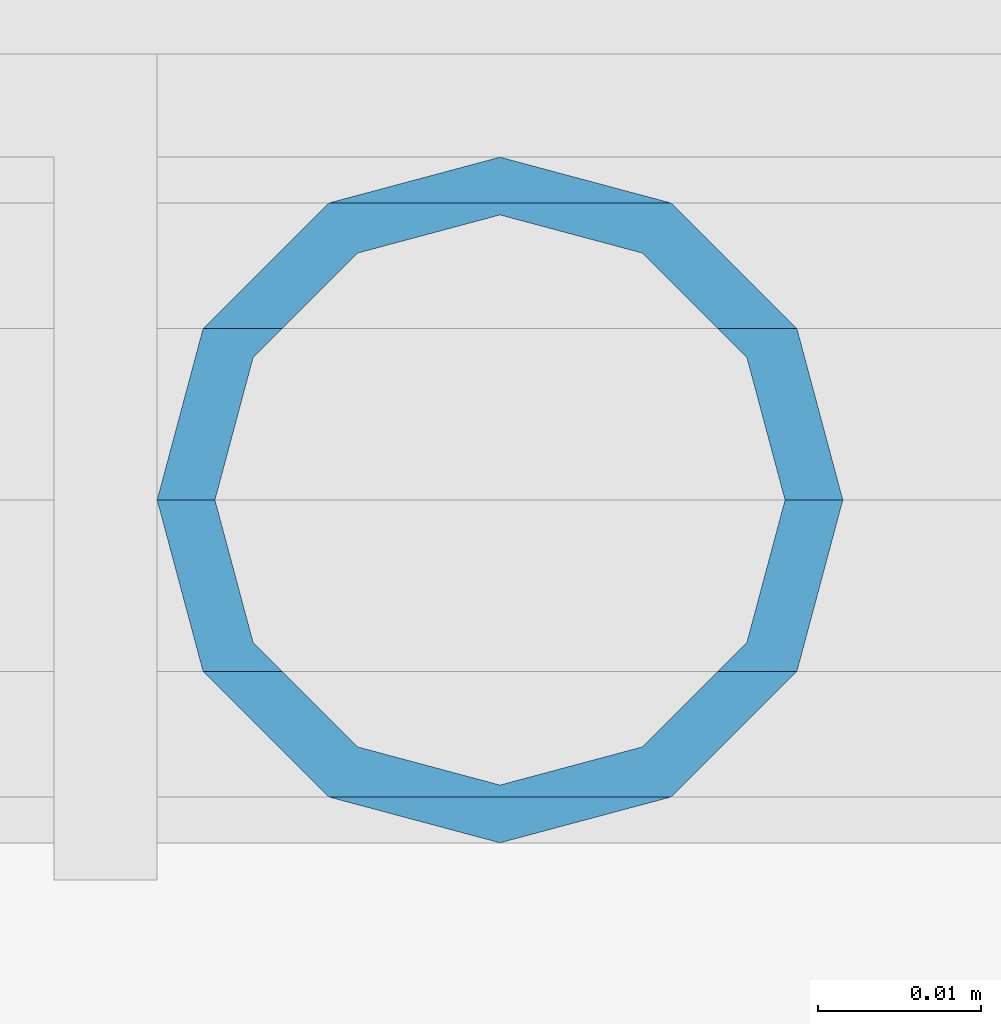
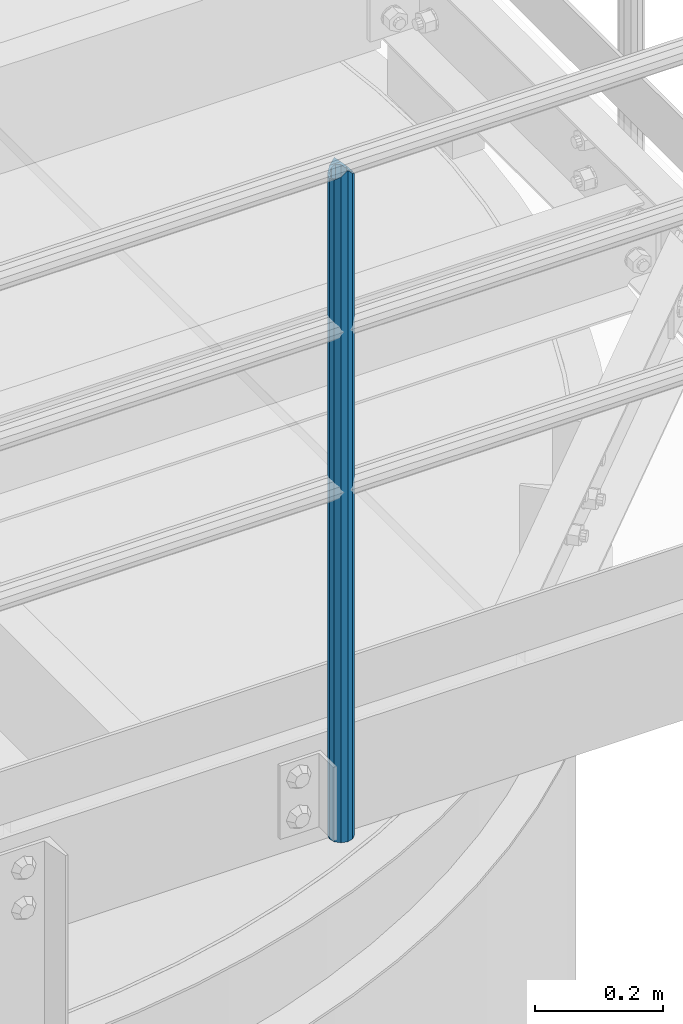
# One storey, part 543 of 1876: 1 column, 1 element without a shape of its own.
"""IFC2X3 building model written with IfcOpenShell, lengths in millimetres."""

from ifc_helpers import new_model, si_unit, frame, origin_with_axes, place, context, subcontext, project, spatial, faceted_brep, material, type_object, element, aggregate, save


model = new_model("IFC2X3")

# Units and contexts
model_context = context("Model", 3, precision=1e-05, world=origin_with_axes())
body_context = subcontext(model_context, "Body", "Model", "MODEL_VIEW")
ifc_project = project(units=[si_unit("LENGTHUNIT", "METRE", prefix="MILLI"), si_unit("AREAUNIT", "SQUARE_METRE"), si_unit("VOLUMEUNIT", "CUBIC_METRE"), si_unit("MASSUNIT", "GRAM", prefix="KILO"), si_unit("TIMEUNIT", "SECOND"), si_unit("PLANEANGLEUNIT", "RADIAN"), si_unit("SOLIDANGLEUNIT", "STERADIAN"), si_unit("THERMODYNAMICTEMPERATUREUNIT", "DEGREE_CELSIUS"), si_unit("LUMINOUSINTENSITYUNIT", "LUMEN")], contexts=[model_context])

# Site, building, storey
site_placement = place(None, origin_with_axes())
site = spatial("IfcSite", under=ifc_project, at=site_placement, CompositionType="ELEMENT")
building_placement = place(site_placement, origin_with_axes())
building = spatial("IfcBuilding", under=site, at=building_placement, Name="Undefined", CompositionType="ELEMENT")
storey_placement = place(building_placement, origin_with_axes())
storey = spatial("IfcBuildingStorey", under=building, at=storey_placement, Name="Undefined", CompositionType="ELEMENT", Elevation=0.0)

# Assembly, column
assembly_placement = place(storey_placement, origin_with_axes())
assembly = element("IfcElementAssembly", 1, at=assembly_placement, inside=storey, Name="HANDRAIL", AssemblyPlace="NOTDEFINED", PredefinedType="RIGID_FRAME")
ifc_material = material()
column_type = type_object("IfcColumnType", Name="PIPE1-1/4STD", PredefinedType="NOTDEFINED")
column_placement = place(assembly_placement, frame((5791.20143150122, -15432.4964042969, 7813.675), z_axis=(0.0, 1.0, 0.0), x_axis=(0.0, 0.0, 1.0)))
column = element("IfcColumn", 2, at=column_placement, type_object=column_type, material=ifc_material, Name="POST", ObjectType="PIPE1-1/4STD", context=body_context, shape_type="Brep", body=[
    faceted_brep([(1276.35, 0.0, -21.0820000000003), (1265.809, 10.5410000000002, -18.2575475625836), (1265.809, -10.5410000000002, -18.2575475625836), (1257.61603877328, 15.1779612267264, 8.76299999999992), (1255.268, 17.5259999999998, 0.0), (1255.268, 21.0820000000003, 0.0), (1258.09245243742, 18.2575475625836, 10.5410000000002), (1258.09245243742, 13.3999612267262, 10.5410000000002), (1258.09245243742, 13.3999612267262, -10.5410000000002), (1258.09245243742, 18.2575475625836, -10.5410000000002), (1257.61603877328, 15.1779612267264, -8.76299999999992), (1262.72937633681, 8.76299999999992, -15.1779612267255), (1265.07741511008, 0.0, -17.5259999999998), (1262.72937633681, -8.76299999999992, -15.1779612267255), (1258.09245243741, -13.3999612267244, -10.541000000002), (1258.09245243742, -18.2575475625836, -10.5409999999993), (1257.61602877145, -15.1779612267264, -8.76300000000083), (1255.268, -17.5259999999998, 0.0), (1255.268, -21.0820000000003, 0.0), (1257.61604877511, -15.1779612267264, 8.76300000000083), (1258.09245243741, -13.399961226728, 10.5409999999983), (1258.09245243742, -18.2575475625836, 10.5409999999993), (1276.35, 0.0, 21.0820000000003), (1265.809, -10.5410000000002, 18.2575475625836), (1265.809, 10.5410000000002, 18.2575475625836), (1262.72941366414, -8.76299999999992, 15.1779612267264), (1265.07745243742, 0.0, 17.5259999999998), (1262.72941366414, 8.76299999999992, 15.1779612267264), (0.0, -18.2575475625836, -10.5409999999993), (0.0, -10.5410000000002, -18.2575475625836), (-4.28826751885936e-09, 0.0, -21.0820000000003), (0.0, 10.5410000000002, -18.2575475625836), (0.0, 18.2575475625836, -10.5409999999993), (9.09494701772928e-13, 21.0820000000003, 0.0), (0.0, 18.2575475625836, 10.5409999999993), (0.0, 10.5410000000002, 18.2575475625836), (0.0, 0.0, 21.0820000000003), (0.0, -18.2575475625836, 10.5409999999993), (9.09494701772928e-13, -21.0820000000003, 0.0), (0.0, -10.5410000000002, 18.2575475625836), (0.0, -15.1779612267264, -8.76300000000083), (0.0, -8.76299999999992, -15.1779612267255), (0.0, 0.0, -17.5259999999998), (0.0, 8.76299999999992, -15.1779612267255), (0.0, 15.1779612267264, -8.76300000000083), (0.0, 17.5259999999998, 0.0), (0.0, 15.1779612267264, 8.76300000000083), (0.0, 8.76299999999992, 15.1779612267255), (0.0, 0.0, 17.5259999999998), (0.0, -8.76299999999992, 15.1779612267255), (0.0, -15.1779612267264, 8.76300000000083), (0.0, -17.5259999999998, 0.0)], [[[0, 1, 2]], [[3, 4, 5, 6, 7]], [[8, 9, 5, 4, 10]], [[2, 1, 9, 8, 11, 12, 13, 14, 15]], [[15, 14, 16, 17, 18]], [[18, 17, 19, 20, 21]], [[22, 23, 24]], [[21, 20, 25, 26, 27, 7, 6, 24, 23]], [[28, 29, 2, 15]], [[29, 30, 0, 2]], [[30, 31, 1, 0]], [[31, 32, 9, 1]], [[32, 33, 5, 9]], [[33, 34, 6, 5]], [[34, 35, 24, 6]], [[35, 36, 22, 24]], [[37, 38, 18, 21]], [[39, 37, 21, 23]], [[36, 39, 23, 22]], [[38, 28, 15, 18]], [[37, 39, 36, 35, 34, 33, 32, 31, 30, 29, 28, 38], [40, 41, 42, 43, 44, 45, 46, 47, 48, 49, 50, 51]], [[49, 48, 26, 25]], [[19, 50, 49, 25, 20]], [[51, 50, 19, 17]], [[40, 51, 17, 16]], [[41, 40, 16, 14, 13]], [[42, 41, 13, 12]], [[43, 42, 12, 11]], [[10, 44, 43, 11, 8]], [[45, 44, 10, 4]], [[46, 45, 4, 3]], [[47, 46, 3, 7, 27]], [[48, 47, 27, 26]]]),
])
aggregate(assembly, [column])

save(model, "model.ifc")
